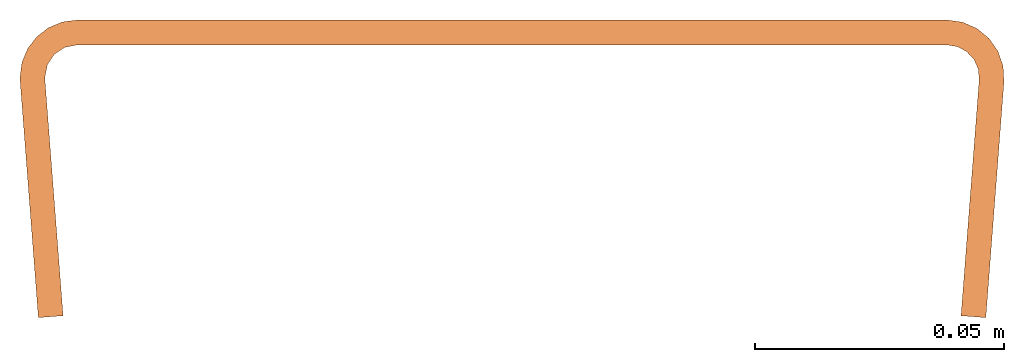
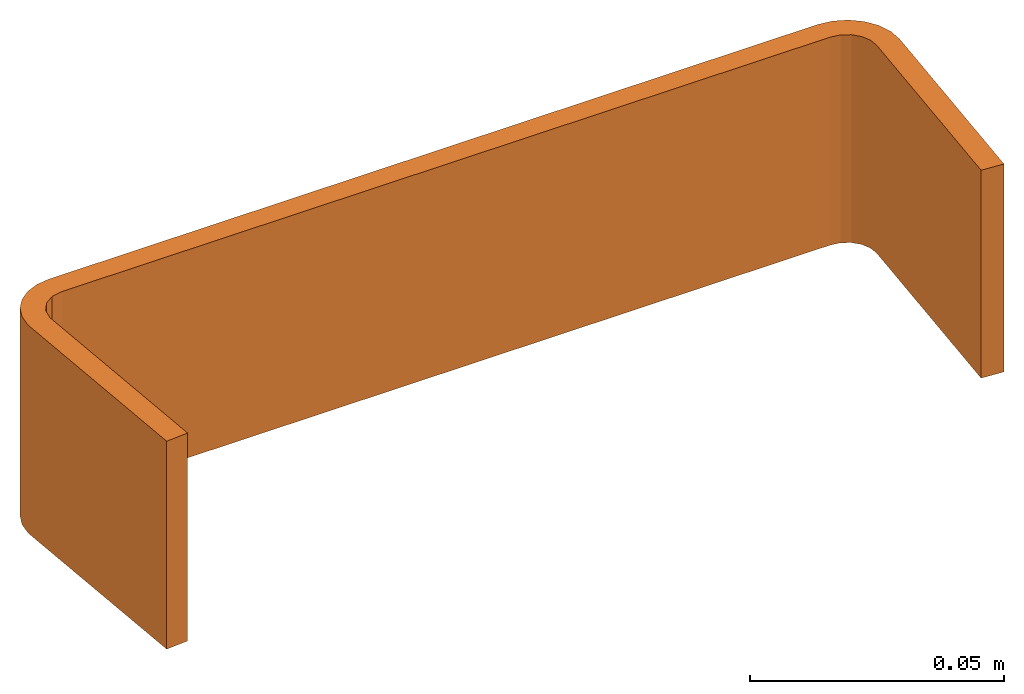
# One storey: 1 proxy.
"""IFC2X3 building model written with IfcOpenShell, lengths in metres."""

from ifc_helpers import new_model, si_unit, direction, origin_with_axes, place, context, project, spatial, faceted_brep, source, transform, mapped, material, element, save


model = new_model("IFC2X3")

# Units and contexts
model_context = context("Model", 3, precision=1e-06, world=origin_with_axes(), true_north=direction((0.0, 1.0, 0.0)))
ifc_project = project(units=[si_unit("LENGTHUNIT", "METRE"), si_unit("AREAUNIT", "SQUARE_METRE"), si_unit("VOLUMEUNIT", "CUBIC_METRE")], contexts=[model_context])

# Site, building, storey
site_placement = place(None, origin_with_axes())
site = spatial("IfcSite", under=ifc_project, at=site_placement, CompositionType="ELEMENT")
building_placement = place(site_placement, origin_with_axes())
building = spatial("IfcBuilding", under=site, at=building_placement, Name="Default Building", CompositionType="ELEMENT")
storey_placement = place(building_placement, origin_with_axes())
storey = spatial("IfcBuildingStorey", under=building, at=storey_placement, Name="Default Storey", CompositionType="ELEMENT", Elevation=0.0)

# Proxy
ifc_material = material(Name="Steel")
shared_shape = source(origin_with_axes(), model_context, "Body", "Brep", [
    faceted_brep([(-0.09286867082118988, 0.019277876242995262, 0.05000000074505806), (-0.09286867082118988, 0.019277876242995262, 0.0), (-0.09237388521432877, 0.021765317767858505, 0.05000000074505806), (-0.09237388521432877, 0.021765317767858505, 0.05000000074505806), (-0.09286867082118988, 0.019277876242995262, 0.0), (-0.09237388521432877, 0.021765317767858505, 0.0), (-0.09237388521432877, 0.021765317767858505, 0.05000000074505806), (-0.09237388521432877, 0.021765317767858505, 0.0), (-0.09096486866474152, 0.02387407049536705, 0.05000000074505806), (-0.09096486866474152, 0.02387407049536705, 0.05000000074505806), (-0.09237388521432877, 0.021765317767858505, 0.0), (-0.09096486866474152, 0.02387407049536705, 0.0), (-0.09096486866474152, 0.02387407049536705, 0.05000000074505806), (-0.09096486866474152, 0.02387407049536705, 0.0), (-0.08885611593723297, 0.025283092632889748, 0.05000000074505806), (-0.08885611593723297, 0.025283092632889748, 0.05000000074505806), (-0.09096486866474152, 0.02387407049536705, 0.0), (-0.08885611593723297, 0.025283092632889748, 0.0), (-0.08885611593723297, 0.025283092632889748, 0.05000000074505806), (-0.08885611593723297, 0.025283092632889748, 0.0), (-0.08636867254972458, 0.025777876377105713, 0.05000000074505806), (-0.08636867254972458, 0.025777876377105713, 0.05000000074505806), (-0.08885611593723297, 0.025283092632889748, 0.0), (-0.08636867254972458, 0.025777876377105713, 0.0), (-0.0978686735033989, 0.019277876242995262, 0.0), (-0.09783479571342468, 0.018395865336060524, 0.0), (-0.0978686735033989, 0.019277876242995262, 0.05000000074505806), (-0.0978686735033989, 0.019277876242995262, 0.05000000074505806), (-0.09783479571342468, 0.018395865336060524, 0.0), (-0.09783479571342468, 0.018395865336060524, 0.05000000074505806), (-0.08885611593723297, 0.025283092632889748, 0.05000000074505806), (-0.08636867254972458, 0.025777876377105713, 0.05000000074505806), (-0.08636867254972458, 0.03077787533402443, 0.05000000074505806), (-0.08636867254972458, 0.03077787533402443, 0.05000000074505806), (-0.08934509009122849, 0.030386023223400116, 0.05000000074505806), (-0.08885611593723297, 0.025283092632889748, 0.05000000074505806), (-0.08885611593723297, 0.025283092632889748, 0.05000000074505806), (-0.08934509009122849, 0.030386023223400116, 0.05000000074505806), (-0.09211867302656174, 0.0292371679097414, 0.05000000074505806), (-0.08885611593723297, 0.025283092632889748, 0.05000000074505806), (-0.09211867302656174, 0.0292371679097414, 0.05000000074505806), (-0.09096486866474152, 0.02387407049536705, 0.05000000074505806), (-0.09096486866474152, 0.02387407049536705, 0.05000000074505806), (-0.09211867302656174, 0.0292371679097414, 0.05000000074505806), (-0.09450040012598038, 0.02740960381925106, 0.05000000074505806), (-0.09096486866474152, 0.02387407049536705, 0.05000000074505806), (-0.09450040012598038, 0.02740960381925106, 0.05000000074505806), (-0.09237388521432877, 0.021765317767858505, 0.05000000074505806), (-0.09783479571342468, 0.018395865336060524, 0.05000000074505806), (-0.09284952282905579, 0.018779348582029343, 0.05000000074505806), (-0.0978686735033989, 0.019277876242995262, 0.05000000074505806), (-0.0978686735033989, 0.019277876242995262, 0.05000000074505806), (-0.09284952282905579, 0.018779348582029343, 0.05000000074505806), (-0.09286867082118988, 0.019277876242995262, 0.05000000074505806), (-0.0978686735033989, 0.019277876242995262, 0.05000000074505806), (-0.09286867082118988, 0.019277876242995262, 0.05000000074505806), (-0.09747681766748428, 0.02225429378449917, 0.05000000074505806), (-0.09747681766748428, 0.02225429378449917, 0.05000000074505806), (-0.09286867082118988, 0.019277876242995262, 0.05000000074505806), (-0.09237388521432877, 0.021765317767858505, 0.05000000074505806), (-0.09747681766748428, 0.02225429378449917, 0.05000000074505806), (-0.09237388521432877, 0.021765317767858505, 0.05000000074505806), (-0.09632796049118042, 0.02502787485718727, 0.05000000074505806), (-0.09632796049118042, 0.02502787485718727, 0.05000000074505806), (-0.09237388521432877, 0.021765317767858505, 0.05000000074505806), (-0.09450040012598038, 0.02740960381925106, 0.05000000074505806), (-0.08636867254972458, 0.025777876377105713, 0.05000000074505806), (0.08843366801738739, 0.025777876377105713, 0.05000000074505806), (-0.08636867254972458, 0.03077787533402443, 0.05000000074505806), (-0.08636867254972458, 0.03077787533402443, 0.05000000074505806), (0.08843366801738739, 0.025777876377105713, 0.05000000074505806), (0.08843366801738739, 0.03077787533402443, 0.05000000074505806), (-0.09286867082118988, 0.019277876242995262, 0.0), (-0.09284952282905579, 0.018779348582029343, 0.0), (-0.09783479571342468, 0.018395865336060524, 0.0), (-0.08636867254972458, 0.03077787533402443, 0.0), (-0.08636867254972458, 0.025777876377105713, 0.0), (-0.08934509009122849, 0.030386023223400116, 0.0), (-0.08934509009122849, 0.030386023223400116, 0.0), (-0.08636867254972458, 0.025777876377105713, 0.0), (-0.08885611593723297, 0.025283092632889748, 0.0), (-0.08934509009122849, 0.030386023223400116, 0.0), (-0.08885611593723297, 0.025283092632889748, 0.0), (-0.09211867302656174, 0.0292371679097414, 0.0), (-0.09211867302656174, 0.0292371679097414, 0.0), (-0.08885611593723297, 0.025283092632889748, 0.0), (-0.09096486866474152, 0.02387407049536705, 0.0), (-0.09783479571342468, 0.018395865336060524, 0.0), (-0.0978686735033989, 0.019277876242995262, 0.0), (-0.09286867082118988, 0.019277876242995262, 0.0), (-0.09286867082118988, 0.019277876242995262, 0.0), (-0.0978686735033989, 0.019277876242995262, 0.0), (-0.09747681766748428, 0.02225429378449917, 0.0), (-0.09286867082118988, 0.019277876242995262, 0.0), (-0.09747681766748428, 0.02225429378449917, 0.0), (-0.09237388521432877, 0.021765317767858505, 0.0), (-0.09237388521432877, 0.021765317767858505, 0.0), (-0.09747681766748428, 0.02225429378449917, 0.0), (-0.09632796049118042, 0.02502787485718727, 0.0), (-0.09237388521432877, 0.021765317767858505, 0.0), (-0.09632796049118042, 0.02502787485718727, 0.0), (-0.09096486866474152, 0.02387407049536705, 0.0), (-0.09096486866474152, 0.02387407049536705, 0.0), (-0.09632796049118042, 0.02502787485718727, 0.0), (-0.09450040012598038, 0.02740960381925106, 0.0), (-0.09096486866474152, 0.02387407049536705, 0.0), (-0.09450040012598038, 0.02740960381925106, 0.0), (-0.09211867302656174, 0.0292371679097414, 0.0), (-0.09284952282905579, 0.018779348582029343, 0.0), (-0.08920019865036011, -0.028661910444498062, 0.0), (-0.09783479571342468, 0.018395865336060524, 0.0), (-0.09783479571342468, 0.018395865336060524, 0.0), (-0.08920019865036011, -0.028661910444498062, 0.0), (-0.094185471534729, -0.02904539369046688, 0.0), (0.0949145257472992, 0.018779348582029343, 0.05000000074505806), (0.09989979863166809, 0.018395865336060524, 0.05000000074505806), (0.09472716599702835, 0.020903263241052628, 0.05000000074505806), (0.09472716599702835, 0.020903263241052628, 0.05000000074505806), (0.09989979863166809, 0.018395865336060524, 0.05000000074505806), (0.09970938414335251, 0.021538028493523598, 0.05000000074505806), (0.09472716599702835, 0.020903263241052628, 0.05000000074505806), (0.09970938414335251, 0.021538028493523598, 0.05000000074505806), (0.0938626304268837, 0.022852284833788872, 0.05000000074505806), (0.08843366801738739, 0.03077787533402443, 0.05000000074505806), (0.08843366801738739, 0.025777876377105713, 0.05000000074505806), (0.09155197441577911, 0.030347030609846115, 0.05000000074505806), (0.09155197441577911, 0.030347030609846115, 0.05000000074505806), (0.08843366801738739, 0.025777876377105713, 0.05000000074505806), (0.09053695946931839, 0.025428174063563347, 0.05000000074505806), (0.09155197441577911, 0.030347030609846115, 0.05000000074505806), (0.09053695946931839, 0.025428174063563347, 0.05000000074505806), (0.09443662315607071, 0.029086776077747345, 0.05000000074505806), (0.09443662315607071, 0.029086776077747345, 0.05000000074505806), (0.09053695946931839, 0.025428174063563347, 0.05000000074505806), (0.09241393208503723, 0.02441670000553131, 0.05000000074505806), (0.09443662315607071, 0.029086776077747345, 0.05000000074505806), (0.09241393208503723, 0.02441670000553131, 0.05000000074505806), (0.09687147289514542, 0.02709154598414898, 0.05000000074505806), (0.09687147289514542, 0.02709154598414898, 0.05000000074505806), (0.09241393208503723, 0.02441670000553131, 0.05000000074505806), (0.0938626304268837, 0.022852284833788872, 0.05000000074505806), (0.09687147289514542, 0.02709154598414898, 0.05000000074505806), (0.0938626304268837, 0.022852284833788872, 0.05000000074505806), (0.09867408871650696, 0.024510839954018593, 0.05000000074505806), (0.09867408871650696, 0.024510839954018593, 0.05000000074505806), (0.0938626304268837, 0.022852284833788872, 0.05000000074505806), (0.09970938414335251, 0.021538028493523598, 0.05000000074505806), (0.0949145257472992, 0.018779348582029343, 0.05000000074505806), (0.09126519411802292, -0.028661910444498062, 0.05000000074505806), (0.09989979863166809, 0.018395865336060524, 0.05000000074505806), (0.09989979863166809, 0.018395865336060524, 0.05000000074505806), (0.09126519411802292, -0.028661910444498062, 0.05000000074505806), (0.09625046700239182, -0.02904539369046688, 0.05000000074505806), (0.09989979863166809, 0.018395865336060524, 0.0), (0.0949145257472992, 0.018779348582029343, 0.0), (0.09970938414335251, 0.021538028493523598, 0.0), (0.09970938414335251, 0.021538028493523598, 0.0), (0.0949145257472992, 0.018779348582029343, 0.0), (0.09472716599702835, 0.020903263241052628, 0.0), (0.09970938414335251, 0.021538028493523598, 0.0), (0.09472716599702835, 0.020903263241052628, 0.0), (0.09867408871650696, 0.024510839954018593, 0.0), (0.09867408871650696, 0.024510839954018593, 0.0), (0.09472716599702835, 0.020903263241052628, 0.0), (0.0938626304268837, 0.022852284833788872, 0.0), (0.09867408871650696, 0.024510839954018593, 0.0), (0.0938626304268837, 0.022852284833788872, 0.0), (0.09687147289514542, 0.02709154598414898, 0.0), (0.09687147289514542, 0.02709154598414898, 0.0), (0.0938626304268837, 0.022852284833788872, 0.0), (0.09241393208503723, 0.02441670000553131, 0.0), (0.08843366801738739, 0.025777876377105713, 0.0), (0.08843366801738739, 0.03077787533402443, 0.0), (0.09053695946931839, 0.025428174063563347, 0.0), (0.09053695946931839, 0.025428174063563347, 0.0), (0.08843366801738739, 0.03077787533402443, 0.0), (0.09155197441577911, 0.030347030609846115, 0.0), (0.09053695946931839, 0.025428174063563347, 0.0), (0.09155197441577911, 0.030347030609846115, 0.0), (0.09241393208503723, 0.02441670000553131, 0.0), (0.09241393208503723, 0.02441670000553131, 0.0), (0.09155197441577911, 0.030347030609846115, 0.0), (0.09443662315607071, 0.029086776077747345, 0.0), (0.09241393208503723, 0.02441670000553131, 0.0), (0.09443662315607071, 0.029086776077747345, 0.0), (0.09687147289514542, 0.02709154598414898, 0.0), (0.08843366801738739, 0.025777876377105713, 0.0), (-0.08636867254972458, 0.025777876377105713, 0.0), (0.08843366801738739, 0.03077787533402443, 0.0), (0.08843366801738739, 0.03077787533402443, 0.0), (-0.08636867254972458, 0.025777876377105713, 0.0), (-0.08636867254972458, 0.03077787533402443, 0.0), (0.09126519411802292, -0.028661910444498062, 0.05000000074505806), (0.0949145257472992, 0.018779348582029343, 0.05000000074505806), (0.09126519411802292, -0.028661910444498062, 0.0), (0.09126519411802292, -0.028661910444498062, 0.0), (0.0949145257472992, 0.018779348582029343, 0.05000000074505806), (0.0949145257472992, 0.018779348582029343, 0.0), (0.09625046700239182, -0.02904539369046688, 0.05000000074505806), (0.09126519411802292, -0.028661910444498062, 0.05000000074505806), (0.09625046700239182, -0.02904539369046688, -2.7755575615628914e-17), (0.09625046700239182, -0.02904539369046688, -2.7755575615628914e-17), (0.09126519411802292, -0.028661910444498062, 0.05000000074505806), (0.09126519411802292, -0.028661910444498062, -2.7755575615628914e-17), (0.09989979863166809, 0.018395865336060524, 0.05000000074505806), (0.09625046700239182, -0.02904539369046688, 0.05000000074505806), (0.09989979863166809, 0.018395865336060524, 0.0), (0.09989979863166809, 0.018395865336060524, 0.0), (0.09625046700239182, -0.02904539369046688, 0.05000000074505806), (0.09625046700239182, -0.02904539369046688, 0.0), (0.09989979863166809, 0.018395865336060524, 0.05000000074505806), (0.09989979863166809, 0.018395865336060524, 0.0), (0.09970938414335251, 0.021538028493523598, 0.0), (0.09989979863166809, 0.018395865336060524, 0.05000000074505806), (0.09970938414335251, 0.021538028493523598, 0.0), (0.09970938414335251, 0.021538028493523598, 0.05000000074505806), (0.09970938414335251, 0.021538028493523598, 0.05000000074505806), (0.09970938414335251, 0.021538028493523598, 0.0), (0.09867408871650696, 0.024510839954018593, 0.0), (0.09970938414335251, 0.021538028493523598, 0.05000000074505806), (0.09867408871650696, 0.024510839954018593, 0.0), (0.09867408871650696, 0.024510839954018593, 0.05000000074505806), (0.09867408871650696, 0.024510839954018593, 0.05000000074505806), (0.09867408871650696, 0.024510839954018593, 0.0), (0.09687147289514542, 0.02709154598414898, 0.0), (0.09867408871650696, 0.024510839954018593, 0.05000000074505806), (0.09687147289514542, 0.02709154598414898, 0.0), (0.09687147289514542, 0.02709154598414898, 0.05000000074505806), (0.09687147289514542, 0.02709154598414898, 0.05000000074505806), (0.09687147289514542, 0.02709154598414898, 0.0), (0.09443662315607071, 0.029086776077747345, 0.0), (0.09687147289514542, 0.02709154598414898, 0.05000000074505806), (0.09443662315607071, 0.029086776077747345, 0.0), (0.09443662315607071, 0.029086776077747345, 0.05000000074505806), (0.09443662315607071, 0.029086776077747345, 0.05000000074505806), (0.09443662315607071, 0.029086776077747345, 0.0), (0.09155197441577911, 0.030347030609846115, 0.0), (0.09443662315607071, 0.029086776077747345, 0.05000000074505806), (0.09155197441577911, 0.030347030609846115, 0.0), (0.09155197441577911, 0.030347030609846115, 0.05000000074505806), (0.09155197441577911, 0.030347030609846115, 0.05000000074505806), (0.09155197441577911, 0.030347030609846115, 0.0), (0.08843366801738739, 0.03077787533402443, 0.0), (0.09155197441577911, 0.030347030609846115, 0.05000000074505806), (0.08843366801738739, 0.03077787533402443, 0.0), (0.08843366801738739, 0.03077787533402443, 0.05000000074505806), (-0.08636867254972458, 0.03077787533402443, 0.05000000074505806), (0.08843366801738739, 0.03077787533402443, 0.05000000074505806), (-0.08636867254972458, 0.03077787533402443, 0.0), (-0.08636867254972458, 0.03077787533402443, 0.0), (0.08843366801738739, 0.03077787533402443, 0.05000000074505806), (0.08843366801738739, 0.03077787533402443, 0.0), (-0.08636867254972458, 0.03077787533402443, 0.05000000074505806), (-0.08636867254972458, 0.03077787533402443, 0.0), (-0.08934509009122849, 0.030386023223400116, 0.0), (-0.08636867254972458, 0.03077787533402443, 0.05000000074505806), (-0.08934509009122849, 0.030386023223400116, 0.0), (-0.08934509009122849, 0.030386023223400116, 0.05000000074505806), (-0.08934509009122849, 0.030386023223400116, 0.05000000074505806), (-0.08934509009122849, 0.030386023223400116, 0.0), (-0.09211867302656174, 0.0292371679097414, 0.0), (-0.08934509009122849, 0.030386023223400116, 0.05000000074505806), (-0.09211867302656174, 0.0292371679097414, 0.0), (-0.09211867302656174, 0.0292371679097414, 0.05000000074505806), (-0.09211867302656174, 0.0292371679097414, 0.05000000074505806), (-0.09211867302656174, 0.0292371679097414, 0.0), (-0.09450040012598038, 0.02740960381925106, 0.0), (-0.09211867302656174, 0.0292371679097414, 0.05000000074505806), (-0.09450040012598038, 0.02740960381925106, 0.0), (-0.09450040012598038, 0.02740960381925106, 0.05000000074505806), (-0.09450040012598038, 0.02740960381925106, 0.05000000074505806), (-0.09450040012598038, 0.02740960381925106, 0.0), (-0.09632796049118042, 0.02502787485718727, 0.0), (-0.09450040012598038, 0.02740960381925106, 0.05000000074505806), (-0.09632796049118042, 0.02502787485718727, 0.0), (-0.09632796049118042, 0.02502787485718727, 0.05000000074505806), (-0.09632796049118042, 0.02502787485718727, 0.05000000074505806), (-0.09632796049118042, 0.02502787485718727, 0.0), (-0.09747681766748428, 0.02225429378449917, 0.0), (-0.09632796049118042, 0.02502787485718727, 0.05000000074505806), (-0.09747681766748428, 0.02225429378449917, 0.0), (-0.09747681766748428, 0.02225429378449917, 0.05000000074505806), (-0.09747681766748428, 0.02225429378449917, 0.05000000074505806), (-0.09747681766748428, 0.02225429378449917, 0.0), (-0.0978686735033989, 0.019277876242995262, 0.0), (-0.09747681766748428, 0.02225429378449917, 0.05000000074505806), (-0.0978686735033989, 0.019277876242995262, 0.0), (-0.0978686735033989, 0.019277876242995262, 0.05000000074505806), (-0.094185471534729, -0.02904539369046688, 0.05000000074505806), (-0.09783479571342468, 0.018395865336060524, 0.05000000074505806), (-0.094185471534729, -0.02904539369046688, 0.0), (-0.094185471534729, -0.02904539369046688, 0.0), (-0.09783479571342468, 0.018395865336060524, 0.05000000074505806), (-0.09783479571342468, 0.018395865336060524, 0.0), (-0.08920019865036011, -0.028661910444498062, 0.05000000074505806), (-0.094185471534729, -0.02904539369046688, 0.05000000074505806), (-0.08920019865036011, -0.028661910444498062, -2.7755575615628914e-17), (-0.08920019865036011, -0.028661910444498062, -2.7755575615628914e-17), (-0.094185471534729, -0.02904539369046688, 0.05000000074505806), (-0.094185471534729, -0.02904539369046688, -2.7755575615628914e-17), (-0.09284952282905579, 0.018779348582029343, 0.05000000074505806), (-0.08920019865036011, -0.028661910444498062, 0.05000000074505806), (-0.09284952282905579, 0.018779348582029343, 0.0), (-0.09284952282905579, 0.018779348582029343, 0.0), (-0.08920019865036011, -0.028661910444498062, 0.05000000074505806), (-0.08920019865036011, -0.028661910444498062, 0.0), (-0.09284952282905579, 0.018779348582029343, 0.05000000074505806), (-0.09284952282905579, 0.018779348582029343, 0.0), (-0.09286867082118988, 0.019277876242995262, 0.05000000074505806), (-0.09286867082118988, 0.019277876242995262, 0.05000000074505806), (-0.09284952282905579, 0.018779348582029343, 0.0), (-0.09286867082118988, 0.019277876242995262, 0.0), (0.08843366801738739, 0.025777876377105713, 0.05000000074505806), (-0.08636867254972458, 0.025777876377105713, 0.05000000074505806), (0.08843366801738739, 0.025777876377105713, 0.0), (0.08843366801738739, 0.025777876377105713, 0.0), (-0.08636867254972458, 0.025777876377105713, 0.05000000074505806), (-0.08636867254972458, 0.025777876377105713, 0.0), (0.08843366801738739, 0.025777876377105713, 0.05000000074505806), (0.08843366801738739, 0.025777876377105713, 0.0), (0.09053695946931839, 0.025428174063563347, 0.05000000074505806), (0.09053695946931839, 0.025428174063563347, 0.05000000074505806), (0.08843366801738739, 0.025777876377105713, 0.0), (0.09053695946931839, 0.025428174063563347, 0.0), (0.09053695946931839, 0.025428174063563347, 0.05000000074505806), (0.09053695946931839, 0.025428174063563347, 0.0), (0.09241393208503723, 0.02441670000553131, 0.05000000074505806), (0.09241393208503723, 0.02441670000553131, 0.05000000074505806), (0.09053695946931839, 0.025428174063563347, 0.0), (0.09241393208503723, 0.02441670000553131, 0.0), (0.09241393208503723, 0.02441670000553131, 0.05000000074505806), (0.09241393208503723, 0.02441670000553131, 0.0), (0.0938626304268837, 0.022852284833788872, 0.05000000074505806), (0.0938626304268837, 0.022852284833788872, 0.05000000074505806), (0.09241393208503723, 0.02441670000553131, 0.0), (0.0938626304268837, 0.022852284833788872, 0.0), (0.0938626304268837, 0.022852284833788872, 0.05000000074505806), (0.0938626304268837, 0.022852284833788872, 0.0), (0.09472716599702835, 0.020903263241052628, 0.05000000074505806), (0.09472716599702835, 0.020903263241052628, 0.05000000074505806), (0.0938626304268837, 0.022852284833788872, 0.0), (0.09472716599702835, 0.020903263241052628, 0.0), (0.09472716599702835, 0.020903263241052628, 0.05000000074505806), (0.09472716599702835, 0.020903263241052628, 0.0), (0.0949145257472992, 0.018779348582029343, 0.05000000074505806), (0.0949145257472992, 0.018779348582029343, 0.05000000074505806), (0.09472716599702835, 0.020903263241052628, 0.0), (0.0949145257472992, 0.018779348582029343, 0.0), (-0.09783479571342468, 0.018395865336060524, 0.05000000074505806), (-0.094185471534729, -0.02904539369046688, 0.05000000074505806), (-0.09284952282905579, 0.018779348582029343, 0.05000000074505806), (-0.09284952282905579, 0.018779348582029343, 0.05000000074505806), (-0.094185471534729, -0.02904539369046688, 0.05000000074505806), (-0.08920019865036011, -0.028661910444498062, 0.05000000074505806), (0.09989979863166809, 0.018395865336060524, 0.0), (0.09625046700239182, -0.02904539369046688, 0.0), (0.0949145257472992, 0.018779348582029343, 0.0), (0.0949145257472992, 0.018779348582029343, 0.0), (0.09625046700239182, -0.02904539369046688, 0.0), (0.09126519411802292, -0.028661910444498062, 0.0)], [[[0, 1, 2]], [[3, 4, 5]], [[6, 7, 8]], [[9, 10, 11]], [[12, 13, 14]], [[15, 16, 17]], [[18, 19, 20]], [[21, 22, 23]], [[24, 25, 26]], [[27, 28, 29]], [[30, 31, 32]], [[33, 34, 35]], [[36, 37, 38]], [[39, 40, 41]], [[42, 43, 44]], [[45, 46, 47]], [[48, 49, 50]], [[51, 52, 53]], [[54, 55, 56]], [[57, 58, 59]], [[60, 61, 62]], [[63, 64, 65]], [[66, 67, 68]], [[69, 70, 71]], [[72, 73, 74]], [[75, 76, 77]], [[78, 79, 80]], [[81, 82, 83]], [[84, 85, 86]], [[87, 88, 89]], [[90, 91, 92]], [[93, 94, 95]], [[96, 97, 98]], [[99, 100, 101]], [[102, 103, 104]], [[105, 106, 107]], [[108, 109, 110]], [[111, 112, 113]], [[114, 115, 116]], [[117, 118, 119]], [[120, 121, 122]], [[123, 124, 125]], [[126, 127, 128]], [[129, 130, 131]], [[132, 133, 134]], [[135, 136, 137]], [[138, 139, 140]], [[141, 142, 143]], [[144, 145, 146]], [[147, 148, 149]], [[150, 151, 152]], [[153, 154, 155]], [[156, 157, 158]], [[159, 160, 161]], [[162, 163, 164]], [[165, 166, 167]], [[168, 169, 170]], [[171, 172, 173]], [[174, 175, 176]], [[177, 178, 179]], [[180, 181, 182]], [[183, 184, 185]], [[186, 187, 188]], [[189, 190, 191]], [[192, 193, 194]], [[195, 196, 197]], [[198, 199, 200]], [[201, 202, 203]], [[204, 205, 206]], [[207, 208, 209]], [[210, 211, 212]], [[213, 214, 215]], [[216, 217, 218]], [[219, 220, 221]], [[222, 223, 224]], [[225, 226, 227]], [[228, 229, 230]], [[231, 232, 233]], [[234, 235, 236]], [[237, 238, 239]], [[240, 241, 242]], [[243, 244, 245]], [[246, 247, 248]], [[249, 250, 251]], [[252, 253, 254]], [[255, 256, 257]], [[258, 259, 260]], [[261, 262, 263]], [[264, 265, 266]], [[267, 268, 269]], [[270, 271, 272]], [[273, 274, 275]], [[276, 277, 278]], [[279, 280, 281]], [[282, 283, 284]], [[285, 286, 287]], [[288, 289, 290]], [[291, 292, 293]], [[294, 295, 296]], [[297, 298, 299]], [[300, 301, 302]], [[303, 304, 305]], [[306, 307, 308]], [[309, 310, 311]], [[312, 313, 314]], [[315, 316, 317]], [[318, 319, 320]], [[321, 322, 323]], [[324, 325, 326]], [[327, 328, 329]], [[330, 331, 332]], [[333, 334, 335]], [[336, 337, 338]], [[339, 340, 341]], [[342, 343, 344]], [[345, 346, 347]], [[348, 349, 350]], [[351, 352, 353]], [[354, 355, 356]], [[357, 358, 359]]]),
])
proxy_placement = place(storey_placement, origin_with_axes())
element("IfcBuildingElementProxy", 1, at=proxy_placement, inside=storey, material=ifc_material, CompositionType="ELEMENT", context=model_context, shape_type="MappedRepresentation", body=[
    mapped(shared_shape, transform((0.0, 0.0, 0.0), scale=1.0)),
])

save(model, "model.ifc")
